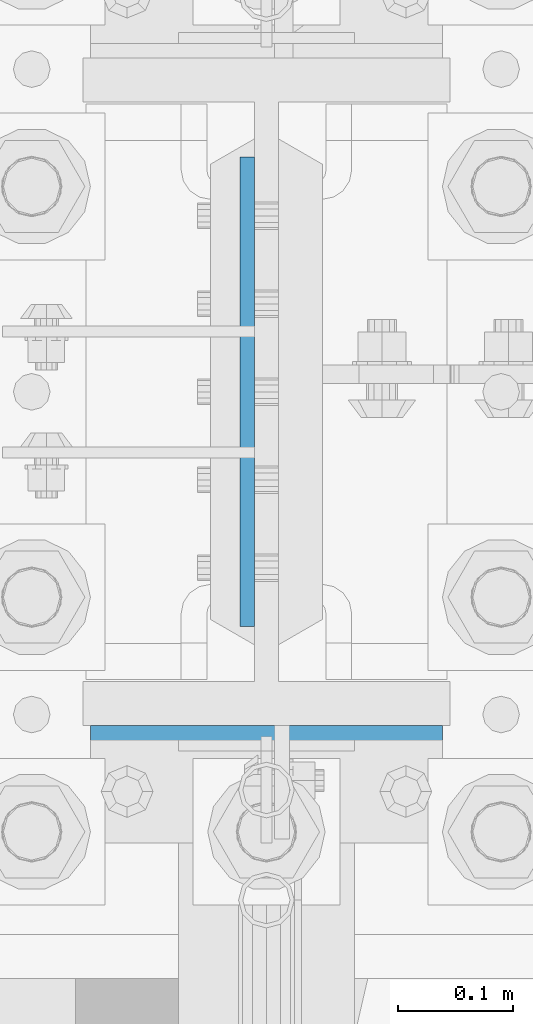
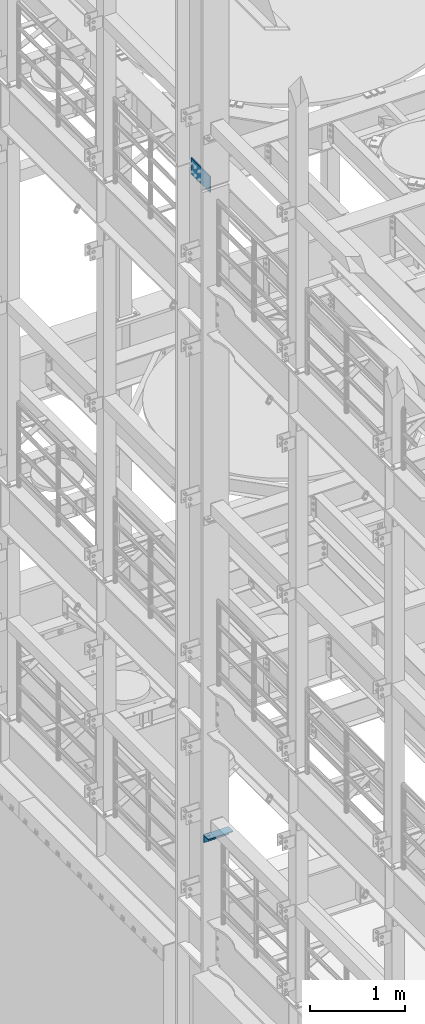
# One storey, part 1289 of 1876: 2 beams, 1 element without a shape of its own.
"""IFC2X3 building model written with IfcOpenShell, lengths in millimetres."""

from ifc_helpers import new_model, si_unit, frame, origin_with_axes, place, context, subcontext, project, spatial, faceted_brep, material, type_object, element, aggregate, save


model = new_model("IFC2X3")

# Units and contexts
model_context = context("Model", 3, precision=1e-05, world=origin_with_axes())
body_context = subcontext(model_context, "Body", "Model", "MODEL_VIEW")
ifc_project = project(units=[si_unit("LENGTHUNIT", "METRE", prefix="MILLI"), si_unit("AREAUNIT", "SQUARE_METRE"), si_unit("VOLUMEUNIT", "CUBIC_METRE"), si_unit("MASSUNIT", "GRAM", prefix="KILO"), si_unit("TIMEUNIT", "SECOND"), si_unit("PLANEANGLEUNIT", "RADIAN"), si_unit("SOLIDANGLEUNIT", "STERADIAN"), si_unit("THERMODYNAMICTEMPERATUREUNIT", "DEGREE_CELSIUS"), si_unit("LUMINOUSINTENSITYUNIT", "LUMEN")], contexts=[model_context])

# Site, building, storey
site_placement = place(None, origin_with_axes())
site = spatial("IfcSite", under=ifc_project, at=site_placement, CompositionType="ELEMENT")
building_placement = place(site_placement, origin_with_axes())
building = spatial("IfcBuilding", under=site, at=building_placement, Name="Undefined", CompositionType="ELEMENT")
storey_placement = place(building_placement, origin_with_axes())
storey = spatial("IfcBuildingStorey", under=building, at=storey_placement, Name="Undefined", CompositionType="ELEMENT", Elevation=0.0)

# Assembly, beams
assembly_placement = place(storey_placement, origin_with_axes())
assembly = element("IfcElementAssembly", 1, at=assembly_placement, inside=storey, Name="COLUMN", AssemblyPlace="NOTDEFINED", PredefinedType="RIGID_FRAME")
ifc_material_1 = material(Name="STEEL/A36")
beam_type_1 = type_object("IfcBeamType", Name="L4X4X3/8", PredefinedType="NOTDEFINED")
beam_1_placement = place(assembly_placement, frame((-152.400000000001, 7280.275, 6194.425), z_axis=(0.0, -1.0, 0.0), x_axis=(1.0, 0.0, 0.0)))
beam_1 = element("IfcBeam", 2, at=beam_1_placement, type_object=beam_type_1, material=ifc_material_1, Name="ANGLE", ObjectType="L4X4X3/8", context=body_context, shape_type="Brep", body=[
    faceted_brep([(0.0, 50.7999999999993, -50.8000000000002), (0.0, 50.7999999999993, 50.8000000000002), (304.799999999999, 50.7999999999993, 50.8000000000002), (304.799999999999, 50.7999999999993, -50.8000000000002), (0.0, 41.2750000000015, 50.8000000000002), (304.799999999999, 41.2750000000015, 50.8000000000002), (0.0, 41.2750000000015, -41.2749999999996), (304.799999999999, 41.2750000000015, -41.2749999999996), (0.0, -50.7999999999993, -41.2749999999996), (304.799999999999, -50.7999999999993, -41.2749999999996), (0.0, -50.7999999999993, -50.8000000000002), (304.799999999999, -50.7999999999993, -50.8000000000002)], [[[0, 1, 2, 3]], [[1, 4, 5, 2]], [[4, 6, 7, 5]], [[6, 8, 9, 7]], [[8, 10, 11, 9]], [[10, 0, 3, 11]], [[5, 7, 9, 11, 3, 2]], [[10, 8, 6, 4, 1, 0]]]),
])
ifc_material_2 = material(Name="STEEL/A572-50")
beam_type_2 = type_object("IfcBeamType", PredefinedType="NOTDEFINED")
beam_2_placement = place(assembly_placement, frame((-16.6687499999999, 7620.0, 14636.75), z_axis=(0.0, 1.0, 0.0), x_axis=(0.0, 0.0, -1.0)))
beam_2 = element("IfcBeam", 3, at=beam_2_placement, type_object=beam_type_2, material=ifc_material_2, Name="PLATE", context=body_context, shape_type="Brep", body=[
    faceted_brep([(0.0, 6.35000000000036, -203.2), (0.0, 6.35000000000036, 203.2), (209.550000000001, 6.35000000000036, 203.2), (209.550000000001, 6.35000000000036, -203.2), (0.0, -6.35000000000036, 203.2), (209.550000000001, -6.35000000000036, 203.2), (0.0, -6.35000000000036, -203.2), (209.550000000001, -6.35000000000036, -203.2)], [[[0, 1, 2, 3]], [[1, 4, 5, 2]], [[4, 6, 7, 5]], [[6, 0, 3, 7]], [[5, 7, 3, 2]], [[6, 4, 1, 0]]]),
])
aggregate(assembly, [beam_1, beam_2])

save(model, "model.ifc")
